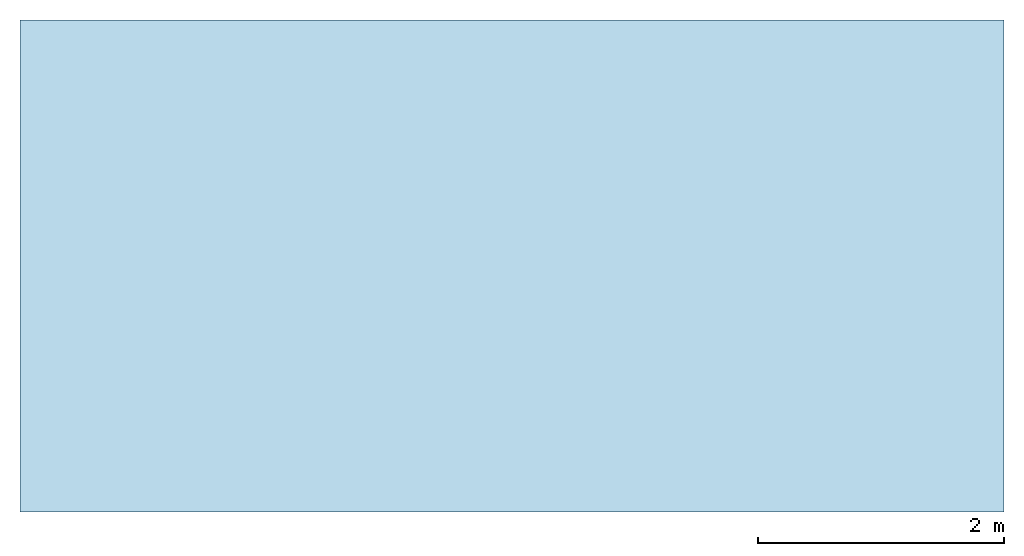
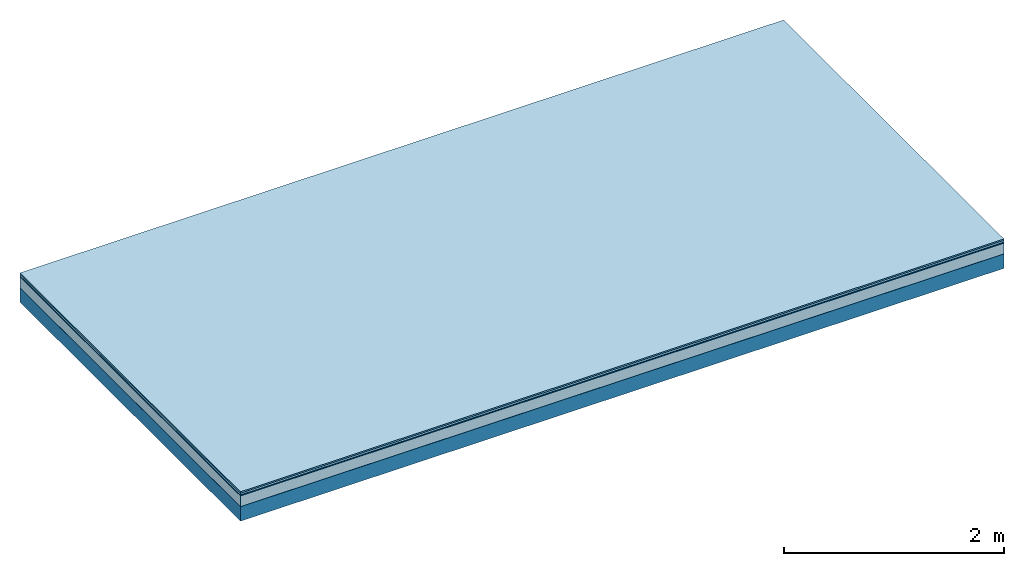
# One storey: 5 plates, 1 member, 1 element without a shape of its own.
"""IFC4 building model written with IfcOpenShell, lengths in metres."""

from ifc_helpers import new_model, si_unit, derived_unit, direction, frame, frame_2d, origin, origin_with_axes, place, context, project, spatial, rectangle, extrude, material, layer, layer_set, type_object, element, aggregate, save


model = new_model("IFC4")

# Units and contexts
plan_context = context("Plan", 3, precision=1e-05, world=origin(), true_north=direction((0.0, 1.0)))
model_context = context("Model", 3, precision=1e-05, world=origin(), true_north=direction((0.0, 1.0)))
ifc_project = project(units=[si_unit("LENGTHUNIT", "METRE"), derived_unit("SOUNDPRESSUREUNIT", [(si_unit("PRESSUREUNIT", "PASCAL", prefix="MICRO"), 0)]), si_unit("ENERGYUNIT", "JOULE", prefix="MEGA"), si_unit("MASSUNIT", "GRAM", prefix="KILO"), derived_unit("THERMALTRANSMITTANCEUNIT", [(si_unit("POWERUNIT", "WATT"), 1), (si_unit("AREAUNIT", "SQUARE_METRE"), -1), (si_unit("THERMODYNAMICTEMPERATUREUNIT", "KELVIN"), -1)]), derived_unit("AREADENSITYUNIT", [(si_unit("MASSUNIT", "GRAM", prefix="KILO"), 1), (si_unit("AREAUNIT", "SQUARE_METRE"), -1)]), derived_unit("USERDEFINED", [(si_unit("ENERGYUNIT", "JOULE", prefix="MEGA"), 1), (si_unit("AREAUNIT", "SQUARE_METRE"), -1)])], contexts=[plan_context, model_context])

# Site, building, storey
site = spatial("IfcSite", under=ifc_project)
building_placement = place(None, origin())
building = spatial("IfcBuilding", under=site, at=building_placement)
storey_placement = place(building_placement, origin())
storey = spatial("IfcBuildingStorey", under=building, at=storey_placement)

# Slab, member, plates
ifc_material_1 = material(Category="11.013")
ifc_layer_1 = layer(ifc_material_1, 0.015, Name="Flooring")
ifc_material_2 = material(Category="03.007")
ifc_layer_2 = layer(ifc_material_2, 0.02, Name="On-material")
ifc_material_3 = material(Name="Wood fiber generic product", Category="10.009")
ifc_layer_3 = layer(ifc_material_3, 0.01, Name="Impact sound insulation")
ifc_material_4 = material(Category="03.011")
ifc_layer_4 = layer(ifc_material_4, 0.12, Name="on Supporting structure")
ifc_material_5 = material(Name="protection", Category="09.007")
ifc_layer_5 = layer(ifc_material_5, 0.0005, Name="Sub-floor")
ifc_material_6 = material(Name="no composite action")
ifc_layer_6 = layer(ifc_material_6, 0.0, Name="Bond")
ifc_layer_7 = layer(None, 0.16, Name="Supporting structure")
ifc_layer_set = layer_set([ifc_layer_1, ifc_layer_2, ifc_layer_3, ifc_layer_4, ifc_layer_5, ifc_layer_6, ifc_layer_7])
slab_type = type_object("IfcSlabType", Name="A2053", PredefinedType="NOTDEFINED", material=ifc_layer_set)
slab_placement = place(None, frame((0.0, 0.0, 0.0), z_axis=(0.0, 0.0, -1.0), x_axis=(1.0, 0.0, 0.0)))
slab = element("IfcSlab", 1, at=slab_placement, inside=storey, type_object=slab_type, material=ifc_layer_set, Name="Slab #1")
ifc_material_7 = material(Name="Solid timber panel")
member_placement = place(slab_placement, origin())
member = element("IfcMember", 2, at=member_placement, material=ifc_material_7, Name="Supporting structure", context=plan_context, shape_type="SweptSolid", body=[
    extrude(rectangle(XDim=1.0, YDim=0.16, at=frame_2d((0.5, 0.08), x_axis=(1.0, 0.0))), frame((0.0, 4.0, 0.1655), z_axis=(0.0, -1.0, 0.0), x_axis=(1.0, 0.0, 0.0)), (0.0, 0.0, 1.0), 4.0),
    extrude(rectangle(XDim=1.0, YDim=0.16, at=frame_2d((0.5, 0.08), x_axis=(1.0, 0.0))), frame((1.0, 4.0, 0.1655), z_axis=(0.0, -1.0, 0.0), x_axis=(1.0, 0.0, 0.0)), (0.0, 0.0, 1.0), 4.0),
    extrude(rectangle(XDim=1.0, YDim=0.16, at=frame_2d((0.5, 0.08), x_axis=(1.0, 0.0))), frame((2.0, 4.0, 0.1655), z_axis=(0.0, -1.0, 0.0), x_axis=(1.0, 0.0, 0.0)), (0.0, 0.0, 1.0), 4.0),
    extrude(rectangle(XDim=1.0, YDim=0.16, at=frame_2d((0.5, 0.08), x_axis=(1.0, 0.0))), frame((3.0, 4.0, 0.1655), z_axis=(0.0, -1.0, 0.0), x_axis=(1.0, 0.0, 0.0)), (0.0, 0.0, 1.0), 4.0),
    extrude(rectangle(XDim=1.0, YDim=0.16, at=frame_2d((0.5, 0.08), x_axis=(1.0, 0.0))), frame((4.0, 4.0, 0.1655), z_axis=(0.0, -1.0, 0.0), x_axis=(1.0, 0.0, 0.0)), (0.0, 0.0, 1.0), 4.0),
    extrude(rectangle(XDim=1.0, YDim=0.16, at=frame_2d((0.5, 0.08), x_axis=(1.0, 0.0))), frame((5.0, 4.0, 0.1655), z_axis=(0.0, -1.0, 0.0), x_axis=(1.0, 0.0, 0.0)), (0.0, 0.0, 1.0), 4.0),
    extrude(rectangle(XDim=1.0, YDim=0.16, at=frame_2d((0.5, 0.08), x_axis=(1.0, 0.0))), frame((6.0, 4.0, 0.1655), z_axis=(0.0, -1.0, 0.0), x_axis=(1.0, 0.0, 0.0)), (0.0, 0.0, 1.0), 4.0),
    extrude(rectangle(XDim=1.0, YDim=0.16, at=frame_2d((0.5, 0.08), x_axis=(1.0, 0.0))), frame((7.0, 4.0, 0.1655), z_axis=(0.0, -1.0, 0.0), x_axis=(1.0, 0.0, 0.0)), (0.0, 0.0, 1.0), 4.0),
])
plate_1_placement = place(slab_placement, origin())
plate_1 = element("IfcPlate", 3, at=plate_1_placement, material=ifc_material_1, Name="Flooring", context=plan_context, shape_type="SweptSolid", body=[
    extrude(rectangle(XDim=8.0, YDim=4.0, at=frame_2d((4.0, 2.0), x_axis=(1.0, 0.0))), origin_with_axes(), (0.0, 0.0, 1.0), 0.015),
])
plate_2_placement = place(slab_placement, origin())
plate_2 = element("IfcPlate", 4, at=plate_2_placement, material=ifc_material_2, Name="On-material", context=plan_context, shape_type="SweptSolid", body=[
    extrude(rectangle(XDim=8.0, YDim=4.0, at=frame_2d((4.0, 2.0), x_axis=(1.0, 0.0))), frame((0.0, 0.0, 0.015), z_axis=(0.0, 0.0, 1.0), x_axis=(1.0, 0.0, 0.0)), (0.0, 0.0, 1.0), 0.02),
])
plate_3_placement = place(slab_placement, origin())
plate_3 = element("IfcPlate", 5, at=plate_3_placement, material=ifc_material_3, Name="Impact sound insulation", context=plan_context, shape_type="SweptSolid", body=[
    extrude(rectangle(XDim=8.0, YDim=4.0, at=frame_2d((4.0, 2.0), x_axis=(1.0, 0.0))), frame((0.0, 0.0, 0.035), z_axis=(0.0, 0.0, 1.0), x_axis=(1.0, 0.0, 0.0)), (0.0, 0.0, 1.0), 0.01),
])
plate_4_placement = place(slab_placement, origin())
plate_4 = element("IfcPlate", 6, at=plate_4_placement, material=ifc_material_4, Name="on Supporting structure", context=plan_context, shape_type="SweptSolid", body=[
    extrude(rectangle(XDim=8.0, YDim=4.0, at=frame_2d((4.0, 2.0), x_axis=(1.0, 0.0))), frame((0.0, 0.0, 0.045), z_axis=(0.0, 0.0, 1.0), x_axis=(1.0, 0.0, 0.0)), (0.0, 0.0, 1.0), 0.12),
])
plate_5_placement = place(slab_placement, origin())
plate_5 = element("IfcPlate", 7, at=plate_5_placement, material=ifc_material_5, Name="Sub-floor", context=plan_context, shape_type="SweptSolid", body=[
    extrude(rectangle(XDim=8.0, YDim=4.0, at=frame_2d((4.0, 2.0), x_axis=(1.0, 0.0))), frame((0.0, 0.0, 0.165), z_axis=(0.0, 0.0, 1.0), x_axis=(1.0, 0.0, 0.0)), (0.0, 0.0, 1.0), 0.0005),
])
aggregate(slab, [plate_1, plate_2, plate_3, plate_4, plate_5, member])

save(model, "model.ifc")
